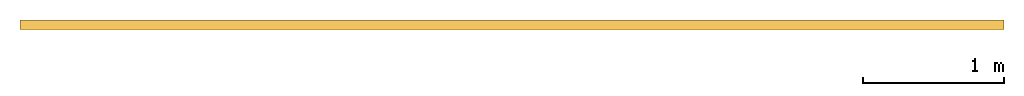
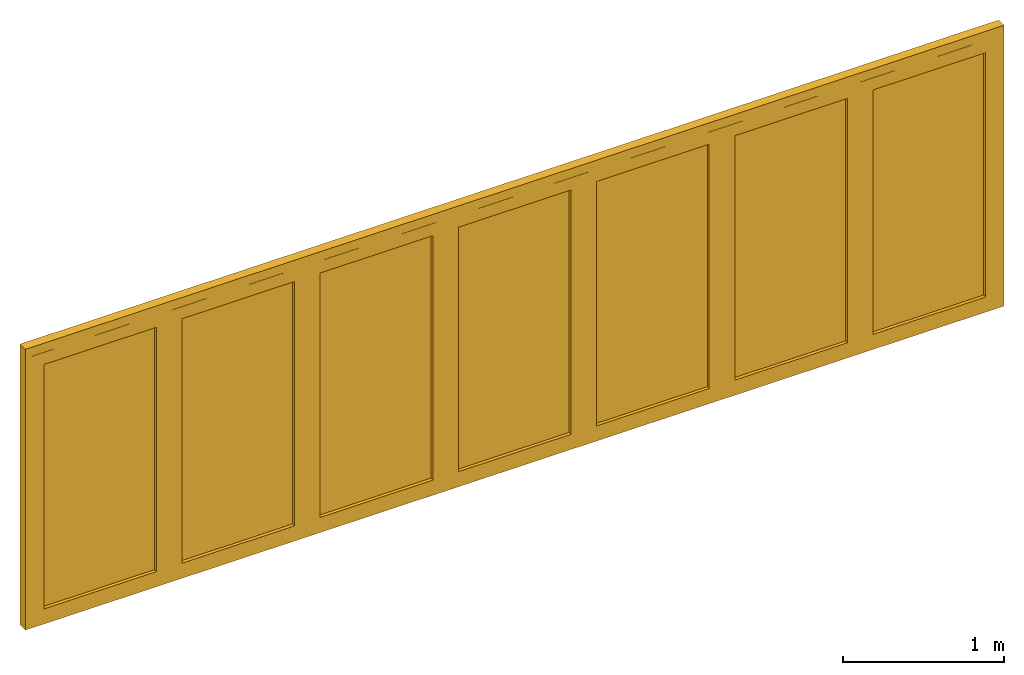
# One storey: 1 door.
"""IFC2X3 building model written with IfcOpenShell, lengths in millimetres."""

from ifc_helpers import new_model, entity, si_unit, converted_unit, direction, frame, frame_2d, origin, origin_2d_with_axis, place, context, subcontext, project, spatial, polyline, rectangle, outline, extrude, source, transform, mapped, material, material_list, type_object, type_shapes, element, save


model = new_model("IFC2X3")

# Units and contexts
model_context = context("Model", 3, precision=1e-06, world=origin(), true_north=direction((2.0, -1.71512652170913e-15, 1.0)))
context_of_model = context(None, 3, precision=1e-06, world=origin(), true_north=direction((2.0, -1.71512652170913e-15, 1.0)))
body_context = subcontext(model_context, "Body", "Model", "MODEL_VIEW")
ifc_project = project(units=[si_unit("LENGTHUNIT", "METRE", prefix="MILLI"), si_unit("AREAUNIT", "SQUARE_METRE", prefix="MILLI"), si_unit("VOLUMEUNIT", "CUBIC_METRE", prefix="MILLI"), converted_unit("PLANEANGLEUNIT", "DEGREE", entity("IfcRatioMeasure", 0.0174532925199433), si_unit("PLANEANGLEUNIT", "RADIAN"), dimensions=[0, 0, 0, 0, 0, 0, 0]), si_unit("TIMEUNIT", "SECOND")], contexts=[model_context, context_of_model])

# Site, building, storey
site_placement = place(None, origin())
site = spatial("IfcSite", under=ifc_project, at=site_placement, CompositionType="ELEMENT")
building_placement = place(site_placement, origin())
building = spatial("IfcBuilding", under=site, at=building_placement, CompositionType="ELEMENT")
storey_placement = place(building_placement, origin())
storey = spatial("IfcBuildingStorey", under=building, at=storey_placement, Name="Ground Floor", CompositionType="ELEMENT", Elevation=0.0)

# Door
ifc_material_1 = material(Name="Glass-Blue")
ifc_material_2 = material(Name="Wd-Pine Vertical")
ifc_material_list = material_list([ifc_material_1, ifc_material_2])
door_style = type_object("IfcDoorStyle", ConstructionType="NOTDEFINED", OperationType="NOTDEFINED", ParameterTakesPrecedence=False, Sizeable=False)
shared_shape = source(origin(), body_context, "Body", "SweptSolid", [
    extrude(rectangle(XDim=805.5714, YDim=18.0, at=frame_2d((0.0, -1.68753899743024e-14), x_axis=(1.0, 0.0))), frame((6916.0291, 266.65, 91.5), z_axis=(0.0, 0.0, 1.0), x_axis=(-1.0, 0.0, 0.0)), (0.0, 0.0, 1.0), 1848.1),
    extrude(outline(polyline([(-494.2857, -1015.55), (494.2857, -1015.55), (494.2857, 1015.55), (-494.2857, 1015.55), (-494.2857, -1015.55)]), holes=[polyline([(402.7857, 924.05), (402.7857, -924.05), (-402.7857, -924.05), (-402.7857, 924.05), (402.7857, 924.05)])]), frame((6916.0291, 233.3, 1015.55), z_axis=(0.0, 1.0, 0.0), x_axis=(-1.0, 0.0, 0.0)), (0.0, 0.0, 1.0), 66.7),
    extrude(rectangle(XDim=805.5715, YDim=18.0, at=frame_2d((-5.40012479177676e-13, -1.68753899743024e-14), x_axis=(1.0, 0.0))), frame((5927.45765, 266.65, 91.5), z_axis=(0.0, 0.0, 1.0), x_axis=(-1.0, 0.0, 0.0)), (0.0, 0.0, 1.0), 1848.1),
    extrude(outline(polyline([(-494.28575, -1015.55), (494.28575, -1015.55), (494.28575, 1015.55), (-494.28575, 1015.55), (-494.28575, -1015.55)]), holes=[polyline([(402.78575, 924.05), (402.78575, -924.05), (-402.785749999999, -924.05), (-402.785749999999, 924.05), (402.78575, 924.05)])]), frame((5927.45765, 233.3, 1015.55), z_axis=(0.0, 1.0, 0.0), x_axis=(-1.0, 0.0, 0.0)), (0.0, 0.0, 1.0), 66.7),
    extrude(rectangle(XDim=805.57139, YDim=18.0, at=frame_2d((2.8421709430404e-13, -1.68753899743024e-14), x_axis=(1.0, 0.0))), frame((4938.886205, 266.65, 91.5), z_axis=(0.0, 0.0, 1.0), x_axis=(-1.0, 0.0, 0.0)), (0.0, 0.0, 1.0), 1848.1),
    extrude(outline(polyline([(-494.285695, -1015.55), (494.285695, -1015.55), (494.285695, 1015.55), (-494.285695, 1015.55), (-494.285695, -1015.55)]), holes=[polyline([(402.785695, 924.05), (402.785695, -924.05), (-402.785695, -924.05), (-402.785695, 924.05), (402.785695, 924.05)])]), frame((4938.886205, 233.3, 1015.55), z_axis=(0.0, 1.0, 0.0), x_axis=(-1.0, 0.0, 0.0)), (0.0, 0.0, 1.0), 66.7),
    extrude(rectangle(XDim=805.57142, YDim=18.0, at=frame_2d((0.0, -1.68753899743024e-14), x_axis=(1.0, 0.0))), frame((3950.3148, 266.65, 91.5), z_axis=(0.0, 0.0, 1.0), x_axis=(-1.0, 0.0, 0.0)), (0.0, 0.0, 1.0), 1848.1),
    extrude(outline(polyline([(-494.285709999999, -1015.55), (494.28571, -1015.55), (494.28571, 1015.55), (-494.285709999999, 1015.55), (-494.285709999999, -1015.55)]), holes=[polyline([(402.785710000001, 924.05), (402.785710000001, -924.05), (-402.78571, -924.05), (-402.78571, 924.05), (402.785710000001, 924.05)])]), frame((3950.3148, 233.3, 1015.55), z_axis=(0.0, 1.0, 0.0), x_axis=(-1.0, 0.0, 0.0)), (0.0, 0.0, 1.0), 66.7),
    extrude(rectangle(XDim=805.57139, YDim=18.0, at=frame_2d((0.0, -1.68753899743024e-14), x_axis=(1.0, 0.0))), frame((2961.743395, 266.65, 91.5), z_axis=(0.0, 0.0, 1.0), x_axis=(-1.0, 0.0, 0.0)), (0.0, 0.0, 1.0), 1848.1),
    extrude(outline(polyline([(-494.285695, -1015.55), (494.285695, -1015.55), (494.285695, 1015.55), (-494.285695, 1015.55), (-494.285695, -1015.55)]), holes=[polyline([(402.785695, 924.05), (402.785695, -924.05), (-402.785695, -924.05), (-402.785695, 924.05), (402.785695, 924.05)])]), frame((2961.743395, 233.3, 1015.55), z_axis=(0.0, 1.0, 0.0), x_axis=(-1.0, 0.0, 0.0)), (0.0, 0.0, 1.0), 66.7),
    extrude(rectangle(XDim=805.5715, YDim=18.0, at=frame_2d((0.0, -1.68753899743024e-14), x_axis=(1.0, 0.0))), frame((1973.17195, 266.65, 91.5), z_axis=(0.0, 0.0, 1.0), x_axis=(-1.0, 0.0, 0.0)), (0.0, 0.0, 1.0), 1848.1),
    extrude(outline(polyline([(-494.28575, -1015.55), (494.28575, -1015.55), (494.28575, 1015.55), (-494.28575, 1015.55), (-494.28575, -1015.55)]), holes=[polyline([(402.78575, 924.05), (402.78575, -924.05), (-402.78575, -924.05), (-402.78575, 924.05), (402.78575, 924.05)])]), frame((1973.17195, 233.3, 1015.55), z_axis=(0.0, 1.0, 0.0), x_axis=(-1.0, 0.0, 0.0)), (0.0, 0.0, 1.0), 66.7),
    extrude(rectangle(XDim=805.5714, YDim=18.0, at=frame_2d((0.0, -1.68753899743024e-14), x_axis=(1.0, 0.0))), frame((984.6005, 266.65, 91.5), z_axis=(0.0, 0.0, 1.0), x_axis=(-1.0, 0.0, 0.0)), (0.0, 0.0, 1.0), 1848.1),
    extrude(outline(polyline([(-494.2857, -1015.55), (494.2857, -1015.55), (494.2857, 1015.55), (-494.2857, 1015.55), (-494.2857, -1015.55)]), holes=[polyline([(402.7857, 924.05), (402.7857, -924.05), (-402.7857, -924.05), (-402.7857, 924.05), (402.7857, 924.05)])]), frame((984.6005, 233.3, 1015.55), z_axis=(0.0, 1.0, 0.0), x_axis=(-1.0, 0.0, 0.0)), (0.0, 0.0, 1.0), 66.7),
    extrude(rectangle(XDim=40.0, YDim=66.0, at=frame_2d((3.37507799486048e-14, 0.0), x_axis=(1.0, 0.0))), frame((470.3148, 267.0, 0.0), z_axis=(0.0, 0.0, 1.0), x_axis=(-1.0, 0.0, 0.0)), (0.0, 0.0, 1.0), 2031.1),
    extrude(rectangle(XDim=39.9999999999996, YDim=66.0, at=origin_2d_with_axis()), frame((7430.3148, 267.0, 0.0), z_axis=(0.0, 0.0, 1.0), x_axis=(-1.0, 0.0, 0.0)), (0.0, 0.0, 1.0), 2031.1),
    extrude(rectangle(XDim=7000.0, YDim=66.0, at=origin_2d_with_axis()), frame((3950.3148, 267.0, 2031.1), z_axis=(0.0, 0.0, 1.0), x_axis=(-1.0, 0.0, 0.0)), (0.0, 0.0, 1.0), 68.9000000000003),
    extrude(rectangle(XDim=7000.0, YDim=66.0, at=origin_2d_with_axis()), frame((3950.3148, 267.0, -23.4), z_axis=(0.0, 0.0, 1.0), x_axis=(-1.0, 0.0, 0.0)), (0.0, 0.0, 1.0), 23.4),
])
type_shapes(door_style, [shared_shape])
door_placement = place(storey_placement, origin())
element("IfcDoor", 1, at=door_placement, inside=storey, type_object=door_style, material=ifc_material_list, OverallHeight=2123.4, OverallWidth=7000.0, context=body_context, shape_type="MappedRepresentation", body=[
    mapped(shared_shape, transform((0.0, 0.0, 0.0), scale=1.0)),
])

save(model, "model.ifc")
